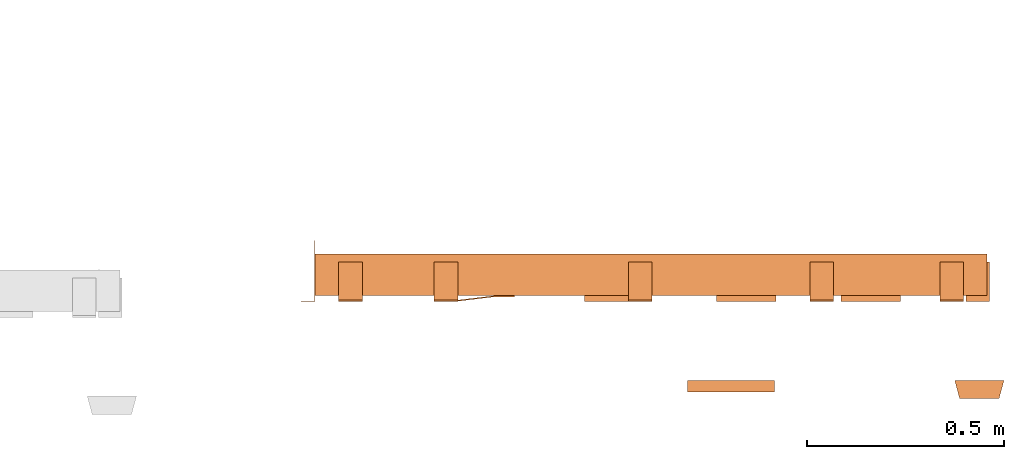
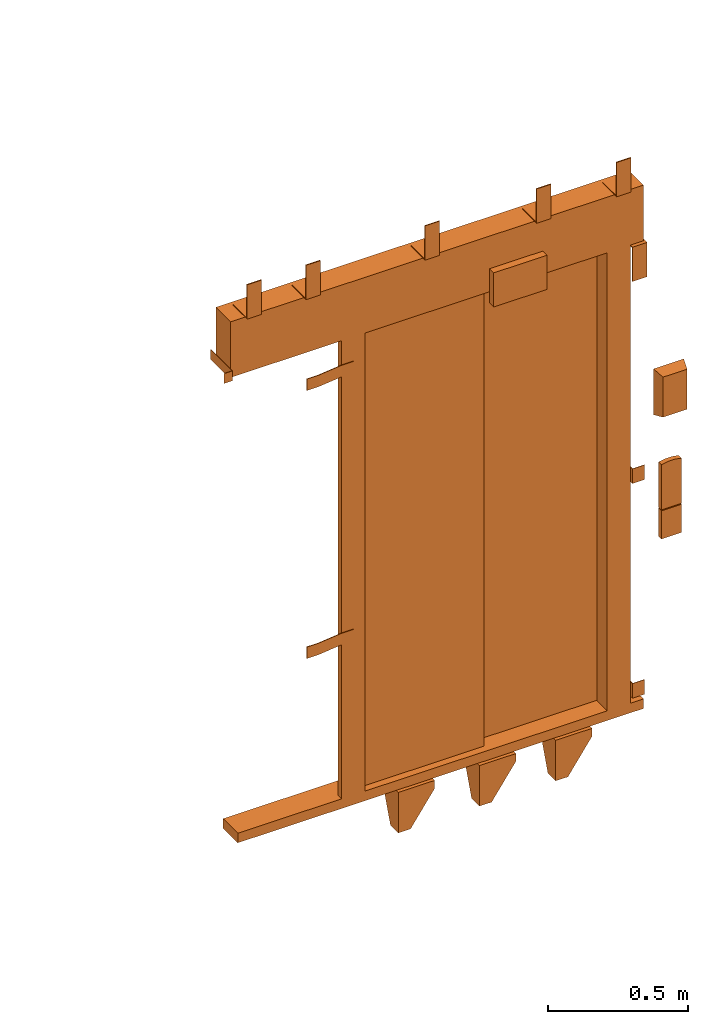
# One storey, part 2 of 2: 1 proxy.
"""IFC2X3 building model written with IfcOpenShell, lengths in millimetres."""

from ifc_helpers import new_model, entity, si_unit, converted_unit, derived_unit, direction, frame, origin, place, context, subcontext, project, spatial, faceted_brep, source, transform, mapped, material, type_object, type_shapes, element, save


model = new_model("IFC2X3")

# Units and contexts
model_context = context("Model", 3, precision=0.01, world=origin(), true_north=direction((6.12303176911189e-17, 1.0)))
body_context = subcontext(model_context, "Body", "Model", "MODEL_VIEW")
ifc_project = project(units=[si_unit("LENGTHUNIT", "METRE", prefix="MILLI"), si_unit("AREAUNIT", "SQUARE_METRE"), si_unit("VOLUMEUNIT", "CUBIC_METRE"), converted_unit("PLANEANGLEUNIT", "DEGREE", entity("IfcRatioMeasure", 0.0174532925199433), si_unit("PLANEANGLEUNIT", "RADIAN"), dimensions=[0, 0, 0, 0, 0, 0, 0]), si_unit("MASSUNIT", "GRAM", prefix="KILO"), derived_unit("MASSDENSITYUNIT", [(si_unit("MASSUNIT", "GRAM", prefix="KILO"), 1), (si_unit("LENGTHUNIT", "METRE"), -3)]), derived_unit("MOMENTOFINERTIAUNIT", [(si_unit("LENGTHUNIT", "METRE"), 4)]), si_unit("TIMEUNIT", "SECOND"), si_unit("FREQUENCYUNIT", "HERTZ"), si_unit("THERMODYNAMICTEMPERATUREUNIT", "DEGREE_CELSIUS"), derived_unit("THERMALTRANSMITTANCEUNIT", [(si_unit("MASSUNIT", "GRAM", prefix="KILO"), 1), (si_unit("THERMODYNAMICTEMPERATUREUNIT", "KELVIN"), -1), (si_unit("TIMEUNIT", "SECOND"), -3)]), derived_unit("VOLUMETRICFLOWRATEUNIT", [(si_unit("LENGTHUNIT", "METRE"), 3), (si_unit("TIMEUNIT", "SECOND"), -1)]), derived_unit("MASSFLOWRATEUNIT", [(si_unit("MASSUNIT", "GRAM", prefix="KILO"), 1), (si_unit("TIMEUNIT", "SECOND"), -1)]), derived_unit("ROTATIONALFREQUENCYUNIT", [(si_unit("TIMEUNIT", "SECOND"), -1)]), si_unit("ELECTRICCURRENTUNIT", "AMPERE"), si_unit("ELECTRICVOLTAGEUNIT", "VOLT"), si_unit("POWERUNIT", "WATT"), si_unit("FORCEUNIT", "NEWTON", prefix="KILO"), si_unit("ILLUMINANCEUNIT", "LUX"), si_unit("LUMINOUSFLUXUNIT", "LUMEN"), si_unit("LUMINOUSINTENSITYUNIT", "CANDELA"), derived_unit("USERDEFINED", [(si_unit("MASSUNIT", "GRAM", prefix="KILO"), -1), (si_unit("LENGTHUNIT", "METRE"), -2), (si_unit("TIMEUNIT", "SECOND"), 3), (si_unit("LUMINOUSFLUXUNIT", "LUMEN"), 1)]), derived_unit("LINEARVELOCITYUNIT", [(si_unit("LENGTHUNIT", "METRE"), 1), (si_unit("TIMEUNIT", "SECOND"), -1)]), si_unit("PRESSUREUNIT", "PASCAL"), derived_unit("USERDEFINED", [(si_unit("LENGTHUNIT", "METRE"), -2), (si_unit("MASSUNIT", "GRAM", prefix="KILO"), 1), (si_unit("TIMEUNIT", "SECOND"), -2)]), derived_unit("LINEARFORCEUNIT", [(si_unit("MASSUNIT", "GRAM", prefix="KILO"), 1), (si_unit("LENGTHUNIT", "METRE"), 1), (si_unit("TIMEUNIT", "SECOND"), -2), (si_unit("LENGTHUNIT", "METRE"), -1)]), derived_unit("PLANARFORCEUNIT", [(si_unit("MASSUNIT", "GRAM", prefix="KILO"), 1), (si_unit("LENGTHUNIT", "METRE"), 1), (si_unit("TIMEUNIT", "SECOND"), -2), (si_unit("LENGTHUNIT", "METRE"), -2)])], contexts=[model_context])

# Site, building, storey
site_placement = place(None, frame((0.0, -0.00077364408347762, 0.0)))
site = spatial("IfcSite", under=ifc_project, at=site_placement, CompositionType="ELEMENT")
building_placement = place(site_placement, origin())
building = spatial("IfcBuilding", under=site, at=building_placement, CompositionType="ELEMENT")
storey_placement = place(building_placement, frame((0.0, 0.0, 19800.0)))
storey = spatial("IfcBuildingStorey", under=building, at=storey_placement, CompositionType="ELEMENT", Elevation=19800.0)

# Proxy
ifc_material = material()
building_element_proxy_type = type_object("IfcBuildingElementProxyType", PredefinedType="NOTDEFINED", material=ifc_material)
shared_shape = source(origin(), body_context, "Body", "Brep", [
    faceted_brep([(11.6733435145681, 105.0, -47.0), (114.5, 33.0, -47.0), (114.5, 5.0, -47.0), (-31.0, 5.0, -47.0), (-31.0, 105.0, -47.0), (11.6733435145681, 105.0, -42.0), (-36.0, 105.0, -42.0), (-36.0, 0.0, -42.0), (114.5, 0.0, -42.0), (114.5, 33.0, -42.0), (-31.0, 105.0, -84.0), (-36.0, 105.0, -84.0), (-36.0, 55.8640183740635, -219.0), (-36.0, 0.0, -219.0), (114.5, 0.0, -76.185199325789), (114.5, 5.0, -76.185199325789), (14.5, 5.0, -219.0), (-31.0, 5.0, -219.0), (14.5, 0.0, -219.0), (-31.0, 55.8640183740635, -219.0)], [[[0, 1, 2, 3, 4]], [[5, 6, 7, 8, 9]], [[6, 5, 0, 4, 10, 11]], [[6, 11, 12, 13, 7]], [[2, 1, 9, 8, 14, 15]], [[1, 0, 5, 9]], [[15, 16, 17, 3, 2]], [[7, 13, 18, 14, 8]], [[16, 15, 14, 18]], [[18, 13, 12, 19, 17, 16]], [[19, 10, 4, 3, 17]], [[12, 11, 10, 19]]]),
    faceted_brep([(-1090.0, 1.5, 2038.5), (-1090.0, 0.0, 2038.5), (-1055.0, 0.0, 2038.5), (-1055.0, 155.0, 2038.5), (-1056.50000000017, 155.0, 2038.5), (-1056.50000000017, 1.5, 2038.5), (-1090.0, 1.5, 1995.5), (-1056.50000000017, 1.5, 1995.5), (-1056.50000000017, 155.0, 1995.5), (-1055.0, 155.0, 1995.5), (-1055.0, 0.0, 1995.5), (-1090.0, 0.0, 1995.5)], [[[0, 1, 2, 3, 4, 5]], [[6, 7, 8, 9, 10, 11]], [[1, 0, 6, 11]], [[2, 1, 11, 10]], [[3, 2, 10, 9]], [[4, 3, 9, 8]], [[5, 4, 8, 7]], [[0, 5, 7, 6]]]),
    faceted_brep([(-749.0, 3.0, 1895.0), (-749.0, 0.0, 1895.0), (-699.0, 0.0, 1895.0), (-599.0, 12.0, 1895.0), (-549.0, 12.0, 1895.0), (-549.0, 15.0, 1895.0), (-599.0, 15.0, 1895.0), (-699.0, 3.0, 1895.0), (-749.0, 3.0, 1845.0), (-699.0, 3.0, 1845.0), (-599.0, 15.0, 1845.0), (-549.0, 15.0, 1845.0), (-549.0, 12.0, 1845.0), (-599.0, 12.0, 1845.0), (-699.0, 0.0, 1845.0), (-749.0, 0.0, 1845.0)], [[[0, 1, 2, 3, 4, 5, 6, 7]], [[8, 9, 10, 11, 12, 13, 14, 15]], [[1, 0, 8, 15]], [[2, 1, 15, 14]], [[3, 2, 14, 13]], [[4, 3, 13, 12]], [[5, 4, 12, 11]], [[6, 5, 11, 10]], [[7, 6, 10, 9]], [[0, 7, 9, 8]]]),
    faceted_brep([(-749.0, 3.0, 725.0), (-749.0, 0.0, 725.0), (-699.0, 0.0, 725.0), (-599.0, 12.0, 725.0), (-549.0, 12.0, 725.0), (-549.0, 15.0, 725.0), (-599.0, 15.0, 725.0), (-699.0, 3.0, 725.0), (-749.0, 3.0, 675.0), (-699.0, 3.0, 675.0), (-599.0, 15.0, 675.0), (-549.0, 15.0, 675.0), (-549.0, 12.0, 675.0), (-599.0, 12.0, 675.0), (-699.0, 0.0, 675.0), (-749.0, 0.0, 675.0)], [[[0, 1, 2, 3, 4, 5, 6, 7]], [[8, 9, 10, 11, 12, 13, 14, 15]], [[1, 0, 8, 15]], [[2, 1, 15, 14]], [[3, 2, 14, 13]], [[4, 3, 13, 12]], [[5, 4, 12, 11]], [[6, 5, 11, 10]], [[7, 6, 10, 9]], [[0, 7, 9, 8]]]),
    faceted_brep([(596.0, 121.0, 95.0), (596.0, 0.0, 95.0), (646.0, 0.0, 95.0), (646.0, 2.0, 95.0), (598.0, 2.0, 95.0), (598.0, 121.0, 95.0), (596.0, 121.0, 31.0), (598.0, 121.0, 31.0), (598.0, 2.0, 31.0), (646.0, 2.0, 31.0), (646.0, 0.0, 31.0), (596.0, 0.0, 31.0)], [[[0, 1, 2, 3, 4, 5]], [[6, 7, 8, 9, 10, 11]], [[1, 0, 6, 11]], [[2, 1, 11, 10]], [[3, 2, 10, 9]], [[4, 3, 9, 8]], [[5, 4, 8, 7]], [[0, 5, 7, 6]]]),
    faceted_brep([(596.0, 121.0, 1032.0), (596.0, 0.0, 1032.0), (646.0, 0.0, 1032.0), (646.0, 2.0, 1032.0), (598.0, 2.0, 1032.0), (598.0, 121.0, 1032.0), (596.0, 121.0, 968.0), (598.0, 121.0, 968.0), (598.0, 2.0, 968.0), (646.0, 2.0, 968.0), (646.0, 0.0, 968.0), (596.0, 0.0, 968.0)], [[[0, 1, 2, 3, 4, 5]], [[6, 7, 8, 9, 10, 11]], [[1, 0, 6, 11]], [[2, 1, 11, 10]], [[3, 2, 10, 9]], [[4, 3, 9, 8]], [[5, 4, 8, 7]], [[0, 5, 7, 6]]]),
    faceted_brep([(326.673343514606, 105.0, -47.0), (429.500000000038, 33.0, -47.0), (429.500000000038, 5.0, -47.0), (284.0, 5.0, -47.0), (284.0, 105.0, -47.0), (326.673343514606, 105.0, -42.0), (279.0, 105.0, -42.0), (279.0, 0.0, -42.0), (429.500000000038, 0.0, -42.0), (429.500000000038, 33.0, -42.0), (284.0, 105.0, -84.0), (279.0, 105.0, -84.0), (279.0, 55.8640183740593, -219.0), (279.0, 0.0, -219.0), (429.500000000038, 0.0, -76.185199325789), (429.500000000038, 5.0, -76.185199325789), (329.500000000038, 5.0, -219.0), (284.0, 5.0, -219.0), (329.500000000038, 0.0, -219.0), (284.0, 55.8640183740593, -219.0)], [[[0, 1, 2, 3, 4]], [[5, 6, 7, 8, 9]], [[6, 5, 0, 4, 10, 11]], [[6, 11, 12, 13, 7]], [[2, 1, 9, 8, 14, 15]], [[1, 0, 5, 9]], [[15, 16, 17, 3, 2]], [[7, 13, 18, 14, 8]], [[16, 15, 14, 18]], [[18, 13, 12, 19, 17, 16]], [[19, 10, 4, 3, 17]], [[12, 11, 10, 19]]]),
    faceted_brep([(-323.32665648547, 105.0, -47.0), (-220.500000000038, 33.0, -47.0), (-220.500000000038, 5.0, -47.0), (-366.0, 5.0, -47.0), (-366.0, 105.0, -47.0), (-323.32665648547, 105.0, -42.0), (-371.0, 105.0, -42.0), (-371.0, 0.0, -42.0), (-220.500000000038, 0.0, -42.0), (-220.500000000038, 33.0, -42.0), (-366.0, 105.0, -84.0), (-371.0, 105.0, -84.0), (-371.0, 55.864018374066, -219.0), (-371.0, 0.0, -219.0), (-220.500000000038, 0.0, -76.185199325789), (-220.500000000038, 5.0, -76.185199325789), (-320.500000000038, 5.0, -219.0), (-366.0, 5.0, -219.0), (-320.500000000038, 0.0, -219.0), (-366.0, 55.864018374066, -219.0)], [[[0, 1, 2, 3, 4]], [[5, 6, 7, 8, 9]], [[6, 5, 0, 4, 10, 11]], [[6, 11, 12, 13, 7]], [[2, 1, 9, 8, 14, 15]], [[1, 0, 5, 9]], [[15, 16, 17, 3, 2]], [[7, 13, 18, 14, 8]], [[16, 15, 14, 18]], [[18, 13, 12, 19, 17, 16]], [[19, 10, 4, 3, 17]], [[12, 11, 10, 19]]]),
    faceted_brep([(656.0, 100.0, 2000.0), (656.0, 0.0, 2000.0), (656.0, 0.0, 1850.0), (656.0, 4.0, 1850.0), (656.0, 4.0, 1996.0), (656.0, 100.0, 1996.0), (596.0, 100.0, 2000.0), (596.0, 100.0, 1996.0), (596.0, 4.0, 1996.0), (596.0, 4.0, 1850.0), (596.0, 0.0, 1850.0), (596.0, 0.0, 2000.0)], [[[0, 1, 2, 3, 4, 5]], [[6, 7, 8, 9, 10, 11]], [[1, 0, 6, 11]], [[2, 1, 11, 10]], [[3, 2, 10, 9]], [[4, 3, 9, 8]], [[5, 4, 8, 7]], [[0, 5, 7, 6]]]),
    faceted_brep([(590.0, 100.0, 2247.0), (590.0, 4.0, 2247.0), (590.0, 4.0, 2393.0), (590.0, 0.0, 2393.0), (590.0, 0.0, 2243.0), (590.0, 100.0, 2243.0), (530.0, 100.0, 2247.0), (530.0, 100.0, 2243.0), (530.0, 0.0, 2243.0), (530.0, 0.0, 2393.0), (530.0, 4.0, 2393.0), (530.0, 4.0, 2247.0)], [[[0, 1, 2, 3, 4, 5]], [[6, 7, 8, 9, 10, 11]], [[1, 0, 6, 11]], [[2, 1, 11, 10]], [[3, 2, 10, 9]], [[4, 3, 9, 8]], [[5, 4, 8, 7]], [[0, 5, 7, 6]]]),
    faceted_brep([(-200.0, 100.0, 2247.0), (-200.0, 4.0, 2247.0), (-200.0, 4.0, 2393.0), (-200.0, 0.0, 2393.0), (-200.0, 0.0, 2243.0), (-200.0, 100.0, 2243.0), (-260.0, 100.0, 2247.0), (-260.0, 100.0, 2243.0), (-260.0, 0.0, 2243.0), (-260.0, 0.0, 2393.0), (-260.0, 4.0, 2393.0), (-260.0, 4.0, 2247.0)], [[[0, 1, 2, 3, 4, 5]], [[6, 7, 8, 9, 10, 11]], [[1, 0, 6, 11]], [[2, 1, 11, 10]], [[3, 2, 10, 9]], [[4, 3, 9, 8]], [[5, 4, 8, 7]], [[0, 5, 7, 6]]]),
    faceted_brep([(-692.5, 100.0, 2247.0), (-692.5, 4.0, 2247.0), (-692.5, 4.0, 2393.0), (-692.5, 0.0, 2393.0), (-692.5, 0.0, 2243.0), (-692.5, 100.0, 2243.0), (-752.5, 100.0, 2247.0), (-752.5, 100.0, 2243.0), (-752.5, 0.0, 2243.0), (-752.5, 0.0, 2393.0), (-752.5, 4.0, 2393.0), (-752.5, 4.0, 2247.0)], [[[0, 1, 2, 3, 4, 5]], [[6, 7, 8, 9, 10, 11]], [[1, 0, 6, 11]], [[2, 1, 11, 10]], [[3, 2, 10, 9]], [[4, 3, 9, 8]], [[5, 4, 8, 7]], [[0, 5, 7, 6]]]),
    faceted_brep([(-935.0, 100.0, 2247.0), (-935.0, 4.0, 2247.0), (-935.0, 4.0, 2393.0), (-935.0, 0.0, 2393.0), (-935.0, 0.0, 2243.0), (-935.0, 100.0, 2243.0), (-995.0, 100.0, 2247.0), (-995.0, 100.0, 2243.0), (-995.0, 0.0, 2243.0), (-995.0, 0.0, 2393.0), (-995.0, 4.0, 2393.0), (-995.0, 4.0, 2247.0)], [[[0, 1, 2, 3, 4, 5]], [[6, 7, 8, 9, 10, 11]], [[1, 0, 6, 11]], [[2, 1, 11, 10]], [[3, 2, 10, 9]], [[4, 3, 9, 8]], [[5, 4, 8, 7]], [[0, 5, 7, 6]]]),
    faceted_brep([(260.0, 100.0, 2247.0), (260.0, 4.0, 2247.0), (260.0, 4.0, 2393.0), (260.0, 0.0, 2393.0), (260.0, 0.0, 2243.0), (260.0, 100.0, 2243.0), (200.0, 100.0, 2247.0), (200.0, 100.0, 2243.0), (200.0, 0.0, 2243.0), (200.0, 0.0, 2393.0), (200.0, 4.0, 2393.0), (200.0, 4.0, 2247.0)], [[[0, 1, 2, 3, 4, 5]], [[6, 7, 8, 9, 10, 11]], [[1, 0, 6, 11]], [[2, 1, 11, 10]], [[3, 2, 10, 9]], [[4, 3, 9, 8]], [[5, 4, 8, 7]], [[0, 5, 7, 6]]]),
    faceted_brep([(680.0, -246.0, 1587.5), (580.0, -246.0, 1587.5), (580.0, -246.0, 1412.5), (680.0, -246.0, 1412.5), (692.500000000055, -200.0, 1600.0), (692.500000000055, -200.0, 1400.0), (567.500000000055, -200.0, 1400.0), (567.500000000055, -200.0, 1600.0)], [[[0, 1, 2, 3]], [[4, 5, 6, 7]], [[4, 7, 1, 0]], [[7, 6, 2, 1]], [[6, 5, 3, 2]], [[5, 4, 0, 3]]]),
    faceted_brep([(671.500000000055, -220.0, 985.0), (588.500000000055, -220.0, 985.0), (588.500000000055, -220.0, 862.0), (671.500000000055, -220.0, 862.0), (671.500000000055, -200.0, 985.0), (671.500000000055, -200.0, 862.0), (588.500000000055, -200.0, 862.0), (588.500000000055, -200.0, 985.0)], [[[0, 1, 2, 3]], [[4, 5, 6, 7]], [[1, 0, 4, 7]], [[2, 1, 7, 6]], [[3, 2, 6, 5]], [[0, 3, 5, 4]]]),
    faceted_brep([(110.0, -200.0, 2274.49999999999), (110.0, -200.0, 2125.49999999999), (-110.0, -200.0, 2125.49999999999), (-110.0, -200.0, 2274.49999999999), (110.0, -230.0, 2274.49999999999), (-110.0, -230.0, 2274.49999999999), (-110.0, -230.0, 2125.49999999999), (110.0, -230.0, 2125.49999999999)], [[[0, 1, 2, 3]], [[4, 5, 6, 7]], [[5, 4, 0, 3]], [[6, 5, 3, 2]], [[7, 6, 2, 1]], [[4, 7, 1, 0]]]),
    faceted_brep([(643.995794237352, -220.0, 1191.34563181984), (616.00420576276, -220.0, 1191.34563181984), (588.500000000055, -220.0, 1186.14489238263), (588.500000000055, -220.0, 989.0), (671.500000000054, -220.0, 989.0), (671.500000000055, -220.0, 1186.14489238263), (671.500000000054, -200.0, 1186.14489238263), (671.500000000054, -200.0, 989.0), (588.500000000055, -200.0, 989.0), (588.500000000056, -200.0, 1186.14489238263), (616.00420576276, -200.0, 1191.34563181984), (643.995794237352, -200.0, 1191.34563181984)], [[[0, 1, 2, 3, 4, 5]], [[6, 7, 8, 9, 10, 11]], [[3, 2, 9, 8]], [[4, 3, 8, 7]], [[5, 4, 7, 6]], [[6, 11, 0, 5]], [[11, 10, 1, 0]], [[10, 9, 2, 1]]]),
    faceted_brep([(500.0, 87.0, 2000.0), (500.0, 15.0, 2000.0), (596.0, 15.0, 2000.0), (596.0, 120.0, 2000.0), (519.0, 120.0, 2000.0), (519.0, 87.0, 2000.0), (500.0, 87.0, 0.0), (500.0, 15.0, 0.0), (596.0, 15.0, 0.0), (596.0, 120.0, 0.0), (519.0, 120.0, 0.0), (519.0, 87.0, 0.0)], [[[0, 1, 2, 3, 4, 5]], [[1, 0, 6, 7]], [[2, 1, 7, 8]], [[3, 2, 8, 9]], [[4, 3, 9, 10]], [[5, 4, 10, 11]], [[0, 5, 11, 6]], [[6, 11, 10, 9, 8, 7]]]),
    faceted_brep([(-500.0, 41.0, 0.0), (-500.0, 15.0, 0.0), (-596.0, 15.0, 0.0), (-596.0, 41.0, 0.0), (-596.0, 41.0, 2000.0), (-500.0, 41.0, 2000.0), (-596.0, 15.0, 2000.0), (-500.0, 15.0, 2000.0)], [[[0, 1, 2, 3]], [[4, 5, 0, 3]], [[6, 4, 3, 2]], [[7, 6, 2, 1]], [[5, 7, 1, 0]], [[5, 4, 6, 7]]]),
    faceted_brep([(650.0, 15.0, 0.0), (650.0, 15.0, -42.0), (650.0, 120.0, -42.0), (650.0, 120.0, 0.0), (-1025.0, 15.0, 0.0), (-1025.0, 120.0, 0.0), (-1025.0, 120.0, -42.0), (-1025.0, 15.0, -42.0)], [[[0, 1, 2, 3]], [[4, 5, 6, 7]], [[1, 0, 4, 7]], [[2, 1, 7, 6]], [[3, 2, 6, 5]], [[0, 3, 5, 4]]]),
    faceted_brep([(650.0, 15.0, 2243.0), (650.0, 15.0, 2000.0), (650.0, 120.0, 2000.0), (650.0, 120.0, 2243.0), (-1055.0, 15.0, 2243.0), (-1055.0, 120.0, 2243.0), (-1055.0, 120.0, 2000.0), (-1055.0, 15.0, 2000.0)], [[[0, 1, 2, 3]], [[4, 5, 6, 7]], [[1, 0, 4, 7]], [[2, 1, 7, 6]], [[3, 2, 6, 5]], [[0, 3, 5, 4]]]),
    faceted_brep([(515.0, 120.0, 2000.0), (-22.0, 120.0, 2000.0), (-22.0, 91.0, 2000.0), (515.0, 91.0, 2000.0), (515.0, 120.0, 0.0), (-22.0, 120.0, 0.0), (-22.0, 91.0, 0.0), (515.0, 91.0, 0.0)], [[[0, 1, 2, 3]], [[1, 0, 4, 5]], [[2, 1, 5, 6]], [[3, 2, 6, 7]], [[0, 3, 7, 4]], [[4, 7, 6, 5]]]),
    faceted_brep([(8.0, 87.0, 0.0), (8.0, 45.0, 0.0), (-530.0, 45.0, 0.0), (-530.0, 87.0, 0.0), (-530.0, 87.0, 2000.0), (8.0, 87.0, 2000.0), (-530.0, 45.0, 2000.0), (8.0, 45.0, 2000.0)], [[[0, 1, 2, 3]], [[4, 5, 0, 3]], [[6, 4, 3, 2]], [[7, 6, 2, 1]], [[5, 7, 1, 0]], [[5, 4, 6, 7]]]),
])
type_shapes(building_element_proxy_type, [shared_shape])
proxy_placement = place(storey_placement, frame((72363.2467457056, 14180.0, -19800.0)))
element("IfcBuildingElementProxy", 1, at=proxy_placement, inside=storey, type_object=building_element_proxy_type, material=ifc_material, context=body_context, shape_type="MappedRepresentation", body=[
    mapped(shared_shape, transform((0.0, 0.0, 0.0), scale=1.0)),
])

save(model, "model.ifc")
